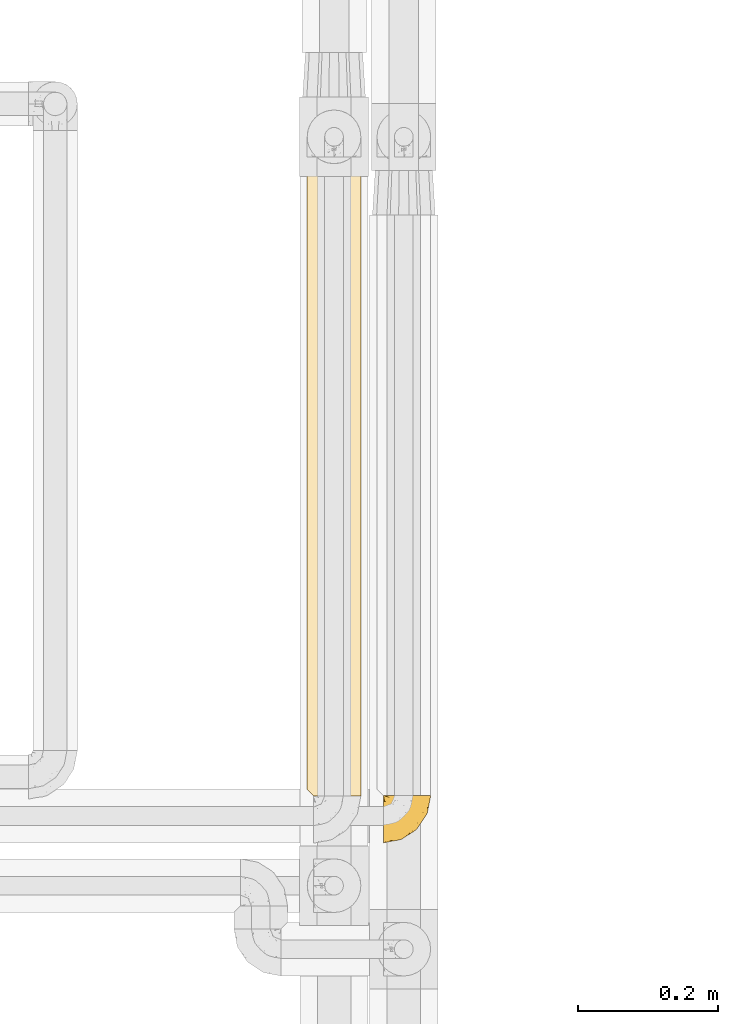
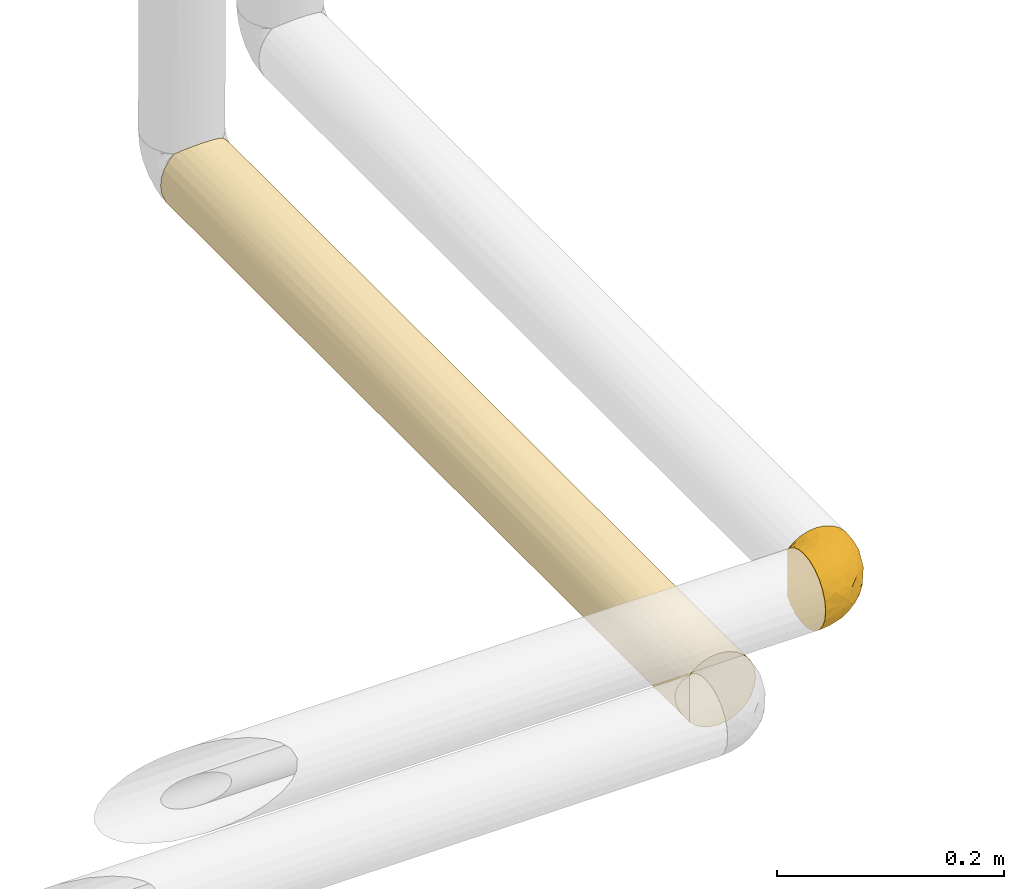
# One storey, part 499 of 827: 2 coverings.
"""IFC2X3 building model written with IfcOpenShell, lengths in millimetres."""

from ifc_helpers import new_model, entity, si_unit, converted_unit, derived_unit, direction, frame, origin, place, context, subcontext, project, spatial, faceted_brep, element, save


model = new_model("IFC2X3")

# Units and contexts
model_context = context("Model", 3, precision=0.01, world=origin(), true_north=direction((6.12303176911189e-17, 1.0)))
body_context = subcontext(model_context, "Body", "Model", "MODEL_VIEW")
ifc_project = project(units=[si_unit("LENGTHUNIT", "METRE", prefix="MILLI"), si_unit("AREAUNIT", "SQUARE_METRE"), si_unit("VOLUMEUNIT", "CUBIC_METRE"), converted_unit("PLANEANGLEUNIT", "DEGREE", entity("IfcRatioMeasure", 0.0174532925199433), si_unit("PLANEANGLEUNIT", "RADIAN"), dimensions=[0, 0, 0, 0, 0, 0, 0]), si_unit("MASSUNIT", "GRAM", prefix="KILO"), derived_unit("MASSDENSITYUNIT", [(si_unit("MASSUNIT", "GRAM", prefix="KILO"), 1), (si_unit("LENGTHUNIT", "METRE"), -3)]), derived_unit("MOMENTOFINERTIAUNIT", [(si_unit("LENGTHUNIT", "METRE"), 4)]), si_unit("TIMEUNIT", "SECOND"), si_unit("FREQUENCYUNIT", "HERTZ"), si_unit("THERMODYNAMICTEMPERATUREUNIT", "DEGREE_CELSIUS"), derived_unit("THERMALTRANSMITTANCEUNIT", [(si_unit("MASSUNIT", "GRAM", prefix="KILO"), 1), (si_unit("THERMODYNAMICTEMPERATUREUNIT", "KELVIN"), -1), (si_unit("TIMEUNIT", "SECOND"), -3)]), derived_unit("VOLUMETRICFLOWRATEUNIT", [(si_unit("LENGTHUNIT", "METRE"), 3), (si_unit("TIMEUNIT", "SECOND"), -1)]), derived_unit("MASSFLOWRATEUNIT", [(si_unit("MASSUNIT", "GRAM", prefix="KILO"), 1), (si_unit("TIMEUNIT", "SECOND"), -1)]), derived_unit("ROTATIONALFREQUENCYUNIT", [(si_unit("TIMEUNIT", "SECOND"), -1)]), si_unit("ELECTRICCURRENTUNIT", "AMPERE"), si_unit("ELECTRICVOLTAGEUNIT", "VOLT"), si_unit("POWERUNIT", "WATT"), si_unit("FORCEUNIT", "NEWTON", prefix="KILO"), si_unit("ILLUMINANCEUNIT", "LUX"), si_unit("LUMINOUSFLUXUNIT", "LUMEN"), si_unit("LUMINOUSINTENSITYUNIT", "CANDELA"), derived_unit("USERDEFINED", [(si_unit("MASSUNIT", "GRAM", prefix="KILO"), -1), (si_unit("LENGTHUNIT", "METRE"), -2), (si_unit("TIMEUNIT", "SECOND"), 3), (si_unit("LUMINOUSFLUXUNIT", "LUMEN"), 1)]), derived_unit("LINEARVELOCITYUNIT", [(si_unit("LENGTHUNIT", "METRE"), 1), (si_unit("TIMEUNIT", "SECOND"), -1)]), si_unit("PRESSUREUNIT", "PASCAL"), derived_unit("USERDEFINED", [(si_unit("LENGTHUNIT", "METRE"), -2), (si_unit("MASSUNIT", "GRAM", prefix="KILO"), 1), (si_unit("TIMEUNIT", "SECOND"), -2)]), derived_unit("LINEARFORCEUNIT", [(si_unit("MASSUNIT", "GRAM", prefix="KILO"), 1), (si_unit("LENGTHUNIT", "METRE"), 1), (si_unit("TIMEUNIT", "SECOND"), -2), (si_unit("LENGTHUNIT", "METRE"), -1)]), derived_unit("PLANARFORCEUNIT", [(si_unit("MASSUNIT", "GRAM", prefix="KILO"), 1), (si_unit("LENGTHUNIT", "METRE"), 1), (si_unit("TIMEUNIT", "SECOND"), -2), (si_unit("LENGTHUNIT", "METRE"), -2)])], contexts=[model_context])

# Site, building, storey
site_placement = place(None, origin())
site = spatial("IfcSite", under=ifc_project, at=site_placement, CompositionType="ELEMENT")
building_placement = place(site_placement, origin())
building = spatial("IfcBuilding", under=site, at=building_placement, CompositionType="ELEMENT")
storey_placement = place(building_placement, frame((0.0, 0.0, 28200.0)))
storey = spatial("IfcBuildingStorey", under=building, at=storey_placement, Name="08", CompositionType="ELEMENT", Elevation=28200.0)

# Coverings
covering_1_placement = place(storey_placement, frame((61121.94, 16439.61, 1059.95)))
element("IfcCovering", 1, at=covering_1_placement, inside=storey, Name=":ADSK_", ObjectType=":ADSK_", PredefinedType="INSULATION", context=body_context, shape_type="Brep", body=[
    faceted_brep([(47.38, 69.15, 74.68), (54.67, 69.15, 70.1), (60.76, 69.15, 64.01), (65.34, 69.15, 56.72), (68.18, 69.15, 48.6), (69.15, 69.15, 40.05), (68.18, 69.15, 31.49), (65.33, 69.15, 23.36), (60.75, 69.15, 16.07), (54.66, 69.15, 9.98), (47.37, 69.15, 5.4), (39.25, 69.15, 2.56), (30.7, 69.15, 1.6), (22.59, 69.15, 2.46), (14.86, 69.15, 5.01), (7.84, 69.15, 9.13), (1.85, 69.15, 14.62), (1.85, 69.15, 16.82), (1.85, 69.15, 18.56), (1.85, 69.15, 20.52), (1.85, 69.15, 22.49), (1.85, 69.15, 24.46), (1.85, 69.15, 26.42), (1.85, 69.15, 28.39), (1.85, 69.15, 30.36), (1.85, 69.15, 32.55), (1.85, 69.15, 34.75), (1.85, 69.15, 36.94), (1.85, 69.15, 39.13), (1.85, 69.15, 41.33), (1.85, 69.15, 43.52), (1.85, 69.15, 45.72), (1.85, 69.15, 47.91), (1.85, 69.15, 50.11), (1.85, 69.15, 52.3), (1.85, 69.15, 54.49), (1.85, 69.15, 56.69), (1.85, 69.15, 58.88), (1.85, 69.15, 61.08), (1.85, 69.15, 63.27), (1.85, 69.15, 65.47), (7.85, 69.15, 70.97), (14.88, 69.15, 75.09), (22.61, 69.15, 77.64), (30.7, 69.15, 78.5), (39.26, 69.15, 77.53), (1.6, 68.89, 14.62), (1.6, 62.89, 9.12), (1.6, 55.87, 5.0), (1.6, 48.14, 2.46), (1.6, 40.05, 1.6), (1.6, 30.09, 2.91), (1.6, 20.82, 6.75), (1.6, 12.86, 12.86), (1.6, 6.75, 20.82), (1.6, 2.91, 30.09), (1.6, 1.6, 40.05), (1.6, 2.91, 50.0), (1.6, 6.75, 59.27), (1.6, 12.86, 67.23), (1.6, 20.82, 73.34), (1.6, 30.09, 77.19), (1.6, 40.05, 78.5), (1.6, 48.14, 77.63), (1.6, 55.87, 75.09), (1.6, 62.89, 70.97), (1.6, 68.89, 65.47), (1.6, 68.89, 63.27), (1.6, 68.89, 62.29), (1.6, 68.89, 60.7), (1.6, 68.89, 59.11), (1.6, 68.89, 57.52), (1.6, 68.89, 55.93), (1.6, 68.89, 54.34), (1.6, 68.89, 52.76), (1.6, 68.89, 51.17), (1.6, 68.89, 49.58), (1.6, 68.89, 47.99), (1.6, 68.89, 46.4), (1.6, 68.89, 44.81), (1.6, 68.89, 43.22), (1.6, 68.89, 41.63), (1.6, 68.89, 40.05), (1.6, 68.89, 38.46), (1.6, 68.89, 36.87), (1.6, 68.89, 35.28), (1.6, 68.89, 33.69), (1.6, 68.89, 32.1), (1.6, 68.89, 30.51), (1.6, 68.89, 28.92), (1.6, 68.89, 27.33), (1.6, 68.89, 25.37), (1.6, 68.89, 23.4), (1.6, 68.89, 21.21), (1.6, 68.89, 19.01), (1.6, 68.89, 16.82), (1.78, 68.97, 42.32), (1.77, 68.96, 44.02), (1.78, 68.97, 47.13), (1.77, 68.97, 48.74), (1.79, 68.98, 23.57), (1.78, 68.97, 25.13), (1.76, 68.96, 61.34), (1.77, 68.96, 22.02), (1.77, 68.96, 29.72), (1.76, 68.96, 56.73), (1.77, 68.96, 55.14), (1.77, 68.96, 37.66), (1.8, 69.0, 64.12), (1.76, 68.96, 28.13), (1.77, 68.96, 26.62), (1.78, 68.97, 31.46), (1.77, 68.96, 16.16), (1.77, 68.96, 39.16), (1.76, 68.96, 50.37), (1.77, 68.97, 17.69), (1.78, 68.97, 19.17), (1.77, 68.97, 62.78), (1.77, 68.96, 58.35), (1.77, 68.96, 45.53), (1.78, 68.97, 59.91), (1.77, 68.97, 65.47), (1.8, 69.02, 65.47), (1.82, 69.08, 65.47), (1.77, 68.97, 14.62), (1.72, 68.94, 14.62), (1.66, 68.92, 14.62), (1.76, 68.96, 20.59), (1.77, 68.96, 32.99), (1.76, 68.95, 34.48), (1.77, 68.96, 51.91), (1.66, 68.92, 65.47), (1.72, 68.94, 65.47), (1.78, 68.98, 53.48), (1.82, 69.08, 14.62), (1.8, 69.02, 14.62), (1.77, 68.96, 40.77), (1.78, 68.97, 35.97), (3.72, 61.33, 7.84), (7.41, 53.1, 3.53), (6.13, 63.33, 8.32), (21.47, 49.27, 1.6), (19.34, 55.53, 2.19), (26.8, 54.6, 1.6), (8.87, 41.99, 1.6), (9.2, 57.07, 4.57), (12.79, 57.95, 3.96), (14.62, 51.56, 2.28), (7.34, 41.58, 1.6), (5.33, 61.7, 7.69), (17.64, 63.33, 3.53), (7.7, 65.0, 8.32), (9.41, 67.02, 7.84), (28.75, 61.87, 1.6), (16.15, 43.94, 1.6), (14.14, 61.21, 4.34), (29.16, 63.4, 1.6), (57.02, 33.11, 29.63), (64.92, 52.82, 27.34), (64.0, 43.3, 40.05), (11.92, 33.73, 2.39), (19.16, 36.52, 2.43), (28.65, 24.87, 9.07), (24.62, 14.17, 16.64), (15.19, 18.43, 9.54), (18.36, 28.67, 4.52), (9.2, 26.0, 4.52), (46.98, 49.25, 7.49), (50.24, 59.72, 7.49), (56.1, 55.1, 12.85), (28.97, 44.72, 2.35), (54.46, 34.15, 22.66), (21.34, 5.25, 32.9), (18.4, 6.75, 25.33), (66.44, 55.54, 40.05), (12.07, 10.47, 16.64), (45.49, 25.49, 19.99), (50.57, 35.53, 16.37), (36.04, 48.22, 3.26), (42.07, 58.71, 3.75), (62.12, 57.42, 19.58), (37.37, 34.84, 7.5), (29.39, 36.87, 4.04), (53.59, 45.01, 13.94), (58.06, 44.4, 19.58), (49.27, 23.96, 28.21), (29.63, 11.2, 24.75), (33.21, 10.56, 31.42), (40.1, 16.81, 26.2), (44.08, 17.38, 33.36), (49.36, 21.38, 40.05), (56.68, 32.34, 40.05), (15.2, 4.3, 40.05), (35.57, 20.65, 16.14), (41.7, 29.66, 12.85), (46.4, 39.6, 10.47), (41.41, 42.55, 6.49), (27.45, 6.74, 40.05), (38.4, 14.06, 40.05), (12.99, 26.84, 75.57), (21.33, 5.28, 47.37), (42.89, 18.52, 52.91), (57.04, 33.13, 50.46), (56.11, 55.1, 67.23), (62.13, 57.43, 60.5), (21.89, 20.72, 70.55), (16.62, 11.46, 63.45), (32.9, 17.69, 62.61), (46.99, 49.26, 72.6), (50.25, 59.73, 72.6), (42.08, 58.71, 76.34), (49.91, 29.72, 59.34), (15.6, 35.35, 77.76), (16.15, 43.94, 78.5), (8.87, 41.99, 78.5), (29.16, 63.4, 78.5), (13.16, 4.93, 53.16), (10.83, 17.46, 70.55), (33.8, 10.94, 48.88), (25.02, 8.92, 54.76), (64.92, 52.83, 52.74), (32.83, 29.34, 71.93), (20.56, 30.26, 75.79), (58.07, 44.4, 60.5), (21.46, 39.06, 77.86), (28.1, 43.06, 77.64), (26.8, 54.6, 78.5), (21.47, 49.27, 78.5), (51.29, 42.69, 67.23), (36.04, 48.2, 76.82), (28.75, 61.87, 78.5), (8.45, 33.44, 77.8), (41.73, 29.67, 67.23), (39.27, 38.5, 73.2), (33.56, 23.35, 67.66), (27.29, 34.97, 75.99), (7.41, 53.1, 76.57), (3.51, 59.68, 73.21), (4.68, 62.19, 71.93), (5.52, 64.11, 71.07), (8.75, 57.97, 75.09), (12.79, 57.95, 76.13), (17.65, 63.33, 76.57), (13.9, 51.77, 77.69), (9.42, 67.02, 72.26), (7.68, 64.98, 71.77), (19.33, 55.53, 77.9), (14.13, 61.22, 75.75)], [[[0, 1, 2, 3, 4, 5, 6, 7, 8, 9, 10, 11, 12, 13, 14, 15, 16, 17, 18, 19, 20, 21, 22, 23, 24, 25, 26, 27, 28, 29, 30, 31, 32, 33, 34, 35, 36, 37, 38, 39, 40, 41, 42, 43, 44, 45]], [[46, 47, 48, 49, 50, 51, 52, 53, 54, 55, 56, 57, 58, 59, 60, 61, 62, 63, 64, 65, 66, 67, 68, 69, 70, 71, 72, 73, 74, 75, 76, 77, 78, 79, 80, 81, 82, 83, 84, 85, 86, 87, 88, 89, 90, 91, 92, 93, 94, 95]], [[96, 97, 30]], [[98, 77, 99]], [[100, 101, 21]], [[69, 68, 102]], [[20, 19, 103]], [[24, 23, 104]], [[20, 103, 100]], [[72, 105, 106]], [[84, 83, 107]], [[89, 88, 104]], [[108, 67, 66]], [[109, 110, 90]], [[111, 25, 24]], [[112, 17, 16]], [[82, 113, 83]], [[109, 23, 22]], [[114, 76, 75]], [[105, 36, 106]], [[104, 111, 24]], [[18, 115, 116]], [[97, 96, 80]], [[67, 108, 117]], [[105, 71, 118]], [[31, 97, 119]], [[102, 120, 69]], [[108, 121, 122, 123, 40]], [[112, 95, 115]], [[17, 115, 18]], [[94, 116, 115]], [[117, 68, 67]], [[38, 117, 39]], [[112, 124, 125, 126, 46]], [[17, 112, 115]], [[70, 120, 118]], [[39, 117, 108]], [[120, 38, 37]], [[120, 37, 118]], [[120, 70, 69]], [[116, 94, 127]], [[128, 86, 129]], [[117, 38, 102]], [[74, 130, 75]], [[99, 33, 32]], [[115, 95, 94]], [[39, 108, 40]], [[108, 66, 131, 132, 121]], [[105, 72, 71]], [[118, 37, 36]], [[71, 70, 118]], [[35, 106, 36]], [[36, 105, 118]], [[35, 133, 106]], [[74, 73, 133]], [[106, 133, 73]], [[99, 114, 33]], [[133, 35, 34]], [[73, 72, 106]], [[95, 112, 46]], [[112, 16, 134, 135, 124]], [[130, 114, 75]], [[99, 76, 114]], [[114, 130, 33]], [[34, 33, 130]], [[78, 77, 98]], [[98, 119, 78]], [[130, 133, 34]], [[133, 130, 74]], [[79, 97, 80]], [[98, 99, 32]], [[98, 32, 31]], [[77, 76, 99]], [[97, 79, 119]], [[136, 96, 29]], [[30, 97, 31]], [[136, 29, 28]], [[81, 80, 96]], [[29, 96, 30]], [[31, 119, 98]], [[119, 79, 78]], [[96, 136, 81]], [[82, 81, 136]], [[113, 107, 83]], [[84, 107, 137]], [[107, 27, 137]], [[113, 28, 107]], [[27, 107, 28]], [[85, 84, 137]], [[137, 27, 26]], [[113, 136, 28]], [[136, 113, 82]], [[109, 89, 104]], [[86, 85, 129]], [[89, 109, 90]], [[111, 87, 128]], [[26, 129, 137]], [[88, 111, 104]], [[25, 111, 128]], [[22, 110, 109]], [[23, 109, 104]], [[110, 91, 90]], [[100, 92, 101]], [[110, 22, 101]], [[91, 110, 101]], [[116, 19, 18]], [[111, 88, 87]], [[127, 103, 19]], [[25, 128, 26]], [[86, 128, 87]], [[128, 129, 26]], [[137, 129, 85]], [[120, 102, 38]], [[117, 102, 68]], [[91, 101, 92]], [[21, 101, 22]], [[93, 92, 103]], [[100, 21, 20]], [[100, 103, 92]], [[127, 93, 103]], [[93, 127, 94]], [[116, 127, 19]], [[126, 138, 47]], [[48, 138, 139]], [[140, 125, 124]], [[141, 142, 143]], [[144, 49, 139]], [[145, 140, 146]], [[48, 139, 49]], [[139, 145, 147]], [[49, 144, 148, 50]], [[126, 125, 149]], [[14, 13, 150]], [[151, 146, 140]], [[149, 140, 145]], [[152, 151, 135]], [[152, 14, 150]], [[16, 15, 134]], [[13, 153, 150]], [[124, 151, 140]], [[141, 147, 142]], [[14, 152, 15]], [[15, 152, 134]], [[47, 46, 126]], [[139, 154, 144]], [[138, 48, 47]], [[125, 140, 149]], [[135, 134, 152]], [[146, 155, 142]], [[145, 146, 147]], [[149, 139, 138]], [[147, 141, 154]], [[147, 146, 142]], [[139, 147, 154]], [[139, 149, 145]], [[149, 138, 126]], [[155, 146, 151]], [[150, 143, 142]], [[152, 155, 151]], [[150, 142, 155]], [[13, 12, 156, 153]], [[153, 143, 150]], [[152, 150, 155]], [[151, 124, 135]], [[157, 158, 159]], [[160, 154, 161]], [[162, 163, 164]], [[165, 166, 160]], [[167, 168, 169]], [[141, 170, 161]], [[156, 12, 11]], [[158, 157, 171]], [[172, 55, 173]], [[158, 6, 174]], [[175, 54, 53]], [[52, 166, 164]], [[52, 164, 53]], [[54, 175, 173]], [[166, 52, 51]], [[176, 177, 171]], [[178, 143, 179]], [[156, 11, 179]], [[8, 7, 180]], [[169, 9, 8]], [[179, 143, 153, 156]], [[179, 11, 10]], [[168, 179, 10]], [[181, 162, 182]], [[179, 167, 178]], [[183, 184, 177]], [[183, 169, 184]], [[176, 171, 185]], [[172, 186, 187]], [[158, 7, 6]], [[159, 158, 174]], [[184, 180, 158]], [[54, 173, 55]], [[180, 169, 8]], [[188, 189, 187]], [[9, 168, 10]], [[186, 188, 187]], [[190, 157, 159, 191]], [[55, 172, 192]], [[176, 193, 194]], [[161, 170, 182]], [[162, 164, 165]], [[175, 164, 163]], [[51, 50, 148]], [[167, 195, 196]], [[178, 182, 170]], [[6, 5, 174]], [[158, 180, 7]], [[169, 180, 184]], [[169, 168, 9]], [[179, 168, 167]], [[182, 162, 165]], [[162, 194, 193]], [[161, 165, 160]], [[195, 181, 196]], [[192, 172, 197]], [[192, 56, 55]], [[189, 190, 198]], [[198, 197, 187]], [[172, 187, 197]], [[185, 189, 188]], [[198, 187, 189]], [[186, 172, 173]], [[173, 163, 186]], [[193, 186, 163]], [[176, 185, 188]], [[185, 157, 190]], [[188, 186, 193]], [[177, 176, 194]], [[188, 193, 176]], [[162, 193, 163]], [[195, 177, 194]], [[171, 177, 184]], [[181, 195, 194]], [[183, 167, 169]], [[162, 181, 194]], [[196, 182, 178]], [[158, 171, 184]], [[171, 157, 185]], [[177, 195, 183]], [[167, 183, 195]], [[182, 196, 181]], [[178, 170, 143]], [[178, 167, 196]], [[164, 175, 53]], [[173, 175, 163]], [[160, 51, 148]], [[164, 166, 165]], [[51, 160, 166]], [[160, 148, 144, 154]], [[141, 161, 154]], [[182, 165, 161]], [[190, 189, 185]], [[143, 170, 141]], [[60, 199, 61]], [[197, 200, 192]], [[201, 190, 202]], [[200, 57, 192]], [[203, 204, 2]], [[205, 206, 207]], [[208, 209, 210]], [[211, 207, 201]], [[212, 213, 214]], [[45, 215, 210]], [[216, 206, 58]], [[45, 44, 215]], [[59, 217, 60]], [[60, 217, 199]], [[0, 45, 210]], [[218, 201, 219]], [[202, 159, 220]], [[205, 221, 222]], [[223, 204, 203]], [[1, 203, 2]], [[57, 200, 216]], [[220, 3, 204]], [[220, 174, 4]], [[1, 0, 209]], [[212, 224, 213]], [[225, 226, 227]], [[228, 223, 203]], [[208, 210, 229]], [[210, 226, 229]], [[3, 220, 4]], [[58, 206, 59]], [[209, 203, 1]], [[202, 220, 223]], [[228, 203, 208]], [[202, 211, 201]], [[3, 2, 204]], [[202, 190, 191, 159]], [[210, 215, 230, 226]], [[199, 212, 231]], [[232, 233, 221]], [[233, 208, 229]], [[207, 206, 219]], [[217, 206, 205]], [[227, 224, 225]], [[233, 232, 228]], [[201, 207, 219]], [[234, 232, 221]], [[218, 219, 200]], [[202, 223, 211]], [[174, 220, 159]], [[174, 5, 4]], [[61, 231, 62]], [[220, 204, 223]], [[210, 209, 0]], [[203, 209, 208]], [[225, 233, 229]], [[224, 227, 213]], [[221, 233, 235]], [[57, 56, 192]], [[198, 218, 197]], [[200, 219, 216]], [[201, 198, 190]], [[197, 218, 200]], [[198, 201, 218]], [[206, 216, 219]], [[58, 57, 216]], [[231, 212, 214]], [[222, 212, 199]], [[228, 211, 223]], [[207, 211, 232]], [[62, 231, 214]], [[199, 231, 61]], [[233, 228, 208]], [[211, 228, 232]], [[222, 221, 235]], [[234, 205, 207]], [[206, 217, 59]], [[199, 217, 205]], [[205, 222, 199]], [[224, 222, 235]], [[222, 224, 212]], [[224, 235, 225]], [[233, 225, 235]], [[226, 225, 229]], [[205, 234, 221]], [[207, 232, 234]], [[63, 214, 236]], [[214, 213, 236]], [[214, 63, 62]], [[237, 236, 238]], [[238, 132, 131]], [[236, 237, 64]], [[239, 240, 241]], [[63, 236, 64]], [[131, 66, 65]], [[237, 131, 65]], [[242, 230, 43]], [[237, 65, 64]], [[239, 121, 132]], [[42, 242, 43]], [[241, 240, 243]], [[41, 123, 244]], [[43, 230, 215, 44]], [[244, 122, 245]], [[227, 246, 243]], [[241, 247, 245]], [[121, 239, 245]], [[41, 40, 123]], [[132, 238, 239]], [[244, 42, 41]], [[131, 237, 238]], [[240, 239, 238]], [[245, 239, 241]], [[247, 241, 246]], [[247, 244, 245]], [[238, 236, 240]], [[243, 236, 213]], [[236, 243, 240]], [[227, 226, 246]], [[243, 213, 227]], [[242, 246, 226]], [[243, 246, 241]], [[246, 242, 247]], [[244, 247, 242]], [[242, 226, 230]], [[42, 244, 242]], [[122, 244, 123]], [[122, 121, 245]]]),
])
covering_2_placement = place(storey_placement, frame((61012.64, 16506.66, 960.01)))
element("IfcCovering", 2, at=covering_2_placement, inside=storey, Name=":ADSK_", ObjectType=":ADSK_", PredefinedType="INSULATION", context=body_context, shape_type="Brep", body=[
    faceted_brep([(31.79, 1.6, 2.48), (40.0, 1.6, 1.6), (49.93, 1.6, 2.9), (59.2, 1.6, 6.74), (67.15, 1.6, 12.84), (73.25, 1.6, 20.8), (77.09, 1.6, 30.06), (78.4, 1.6, 40.0), (77.09, 1.6, 49.93), (73.25, 1.6, 59.2), (67.15, 1.6, 67.15), (59.2, 1.6, 73.25), (49.93, 1.6, 77.09), (40.0, 1.6, 78.4), (31.8, 1.6, 77.51), (23.99, 1.6, 74.9), (16.92, 1.6, 70.69), (10.9, 1.6, 65.06), (10.89, 1.6, 14.95), (16.9, 1.6, 9.32), (23.98, 1.6, 5.1), (30.06, 917.07, 2.9), (20.8, 917.07, 6.74), (12.84, 917.07, 12.84), (6.74, 917.07, 20.8), (2.9, 917.07, 30.06), (1.6, 917.07, 40.0), (2.48, 917.07, 48.2), (5.09, 917.07, 56.01), (9.31, 917.07, 63.08), (14.94, 917.07, 69.1), (65.05, 917.07, 69.1), (70.68, 917.07, 63.08), (74.9, 917.07, 56.01), (77.51, 917.07, 48.2), (78.4, 917.07, 40.0), (77.09, 917.07, 30.06), (73.25, 917.07, 20.8), (67.15, 917.07, 12.84), (59.2, 917.07, 6.74), (49.93, 917.07, 2.9), (40.0, 917.07, 1.6), (2.98, 317.39, 29.79), (1.6, 443.64, 40.0), (2.24, 572.17, 32.99), (4.52, 637.02, 25.3), (9.1, 706.72, 17.2), (13.93, 338.17, 11.79), (3.99, 8.49, 26.64), (2.2, 10.29, 33.21), (25.3, 669.77, 4.52), (14.42, 620.17, 11.35), (29.81, 326.15, 2.97), (40.0, 217.97, 1.6), (5.65, 346.24, 22.81), (1.6, 227.27, 40.0), (8.87, 222.56, 17.51), (6.92, 5.56, 20.49), (8.97, 462.58, 17.37), (32.79, 567.52, 2.28), (40.0, 700.7, 1.6), (1.6, 700.7, 40.0), (20.32, 432.38, 7.02), (40.0, 434.34, 1.6), (20.32, 200.56, 7.02), (1.6, 680.35, 40.0), (1.6, 10.9, 40.0), (63.37, 459.33, 9.53), (54.69, 299.22, 4.52), (54.69, 625.12, 4.52), (63.37, 207.54, 9.53), (70.46, 285.0, 16.62), (47.18, 338.14, 2.27), (46.92, 567.52, 2.23), (63.37, 711.12, 9.53), (70.46, 619.44, 16.62), (77.68, 592.51, 32.61), (75.47, 416.82, 25.3), (75.47, 687.92, 25.3), (76.29, 207.08, 27.45), (77.76, 351.04, 33.03), (78.4, 700.7, 40.0), (78.4, 217.97, 40.0), (78.4, 484.32, 40.0), (78.4, 242.96, 40.0), (72.98, 718.13, 59.66), (76.41, 652.49, 52.17), (57.18, 572.4, 74.33), (54.69, 281.83, 75.47), (62.63, 456.04, 71.02), (76.92, 328.66, 50.54), (68.2, 580.47, 66.05), (46.78, 908.37, 77.79), (40.0, 691.4, 78.4), (50.2, 601.18, 77.01), (73.43, 244.57, 58.88), (72.98, 486.37, 59.66), (68.65, 298.49, 65.56), (62.49, 696.09, 71.11), (40.0, 475.03, 78.4), (47.0, 346.5, 77.75), (53.36, 910.17, 76.0), (62.8, 211.84, 70.89), (40.0, 217.97, 78.4), (59.51, 913.1, 73.07), (40.0, 907.77, 78.4), (33.21, 908.37, 77.79), (2.2, 10.29, 46.79), (8.98, 455.12, 62.64), (8.88, 218.63, 62.5), (15.44, 331.33, 69.52), (27.82, 238.01, 76.41), (11.14, 682.91, 65.33), (23.28, 461.67, 74.57), (29.8, 651.15, 77.02), (23.41, 725.44, 74.63), (26.63, 910.17, 76.0), (17.47, 657.07, 71.1), (30.15, 438.78, 77.11), (6.73, 642.89, 59.18), (5.66, 340.55, 57.18), (6.93, 5.57, 59.52), (20.75, 202.58, 73.22), (20.48, 913.1, 73.07), (3.58, 626.19, 52.17), (2.98, 317.57, 50.21), (4.0, 8.5, 53.36)], [[[0, 1, 2, 3, 4, 5, 6, 7, 8, 9, 10, 11, 12, 13, 14, 15, 16, 17, 18, 19, 20]], [[21, 22, 23, 24, 25, 26, 27, 28, 29, 30, 31, 32, 33, 34, 35, 36, 37, 38, 39, 40, 41]], [[42, 43, 44]], [[45, 24, 46]], [[44, 25, 45]], [[24, 45, 25]], [[18, 47, 19]], [[42, 48, 49]], [[50, 51, 22]], [[0, 52, 53]], [[48, 42, 54]], [[51, 46, 23]], [[49, 55, 42]], [[56, 18, 57]], [[54, 58, 56]], [[52, 50, 59]], [[22, 21, 50]], [[21, 41, 60]], [[54, 45, 58]], [[25, 44, 61]], [[62, 47, 51]], [[63, 53, 52]], [[64, 20, 19]], [[57, 48, 54]], [[0, 53, 1]], [[0, 20, 52]], [[62, 51, 50]], [[56, 58, 47]], [[56, 47, 18]], [[51, 47, 58]], [[20, 64, 52]], [[47, 62, 64]], [[46, 51, 58]], [[22, 51, 23]], [[60, 59, 21]], [[52, 62, 50]], [[59, 60, 63]], [[47, 64, 19]], [[52, 64, 62]], [[44, 43, 65, 61]], [[61, 26, 25]], [[42, 44, 45]], [[52, 59, 63]], [[21, 59, 50]], [[54, 56, 57]], [[45, 54, 42]], [[45, 46, 58]], [[23, 46, 24]], [[55, 49, 66]], [[55, 43, 42]], [[67, 68, 69]], [[70, 71, 4]], [[72, 73, 68]], [[70, 68, 67]], [[39, 69, 40]], [[73, 63, 60]], [[38, 74, 39]], [[2, 53, 72]], [[70, 4, 3]], [[3, 2, 68]], [[37, 75, 38]], [[75, 71, 70, 67, 74]], [[76, 77, 78]], [[78, 75, 37]], [[41, 40, 60]], [[53, 2, 1]], [[79, 77, 80]], [[77, 79, 71]], [[5, 4, 71]], [[36, 78, 37]], [[36, 35, 81]], [[82, 7, 6]], [[63, 73, 72]], [[71, 75, 78, 77]], [[69, 39, 74]], [[79, 80, 82]], [[73, 40, 69]], [[81, 76, 36]], [[80, 77, 76]], [[76, 81, 83]], [[80, 83, 84, 82]], [[36, 76, 78]], [[40, 73, 60]], [[68, 73, 69]], [[68, 2, 72]], [[68, 70, 3]], [[53, 63, 72]], [[75, 74, 38]], [[69, 74, 67]], [[83, 80, 76]], [[79, 82, 6]], [[6, 5, 79]], [[71, 79, 5]], [[85, 86, 33]], [[87, 88, 89]], [[33, 32, 85]], [[83, 86, 90]], [[32, 31, 91]], [[92, 93, 94]], [[34, 86, 81]], [[8, 90, 95]], [[96, 91, 97]], [[96, 90, 86]], [[8, 84, 90]], [[91, 31, 98]], [[94, 99, 100]], [[101, 94, 87]], [[95, 97, 9]], [[34, 33, 86]], [[97, 102, 10]], [[94, 101, 92]], [[86, 83, 81]], [[87, 89, 98]], [[11, 102, 88]], [[98, 89, 91]], [[99, 103, 100]], [[88, 12, 11]], [[104, 101, 87]], [[97, 95, 96]], [[104, 98, 31]], [[81, 35, 34]], [[13, 12, 103]], [[97, 91, 89]], [[91, 96, 85]], [[102, 97, 89]], [[9, 97, 10]], [[91, 85, 32]], [[86, 85, 96]], [[100, 12, 88]], [[12, 100, 103]], [[94, 100, 88]], [[87, 98, 104]], [[88, 87, 94]], [[88, 102, 89]], [[10, 102, 11]], [[8, 95, 9]], [[90, 96, 95]], [[93, 92, 105]], [[93, 99, 94]], [[8, 7, 82, 84]], [[84, 83, 90]], [[105, 106, 93]], [[107, 55, 66]], [[108, 109, 110]], [[14, 111, 15]], [[112, 30, 29]], [[113, 114, 115]], [[114, 106, 116]], [[17, 110, 109]], [[117, 110, 113]], [[118, 114, 113]], [[116, 115, 114]], [[119, 108, 112]], [[14, 103, 111]], [[120, 121, 109]], [[15, 111, 122]], [[120, 109, 108]], [[123, 30, 117]], [[124, 125, 120]], [[27, 124, 28]], [[93, 106, 114]], [[125, 55, 107]], [[27, 65, 124]], [[121, 17, 109]], [[117, 115, 123]], [[43, 125, 124]], [[126, 125, 107]], [[28, 124, 119]], [[126, 121, 120]], [[117, 112, 110]], [[14, 13, 103]], [[112, 108, 110]], [[110, 17, 16]], [[93, 114, 99]], [[122, 16, 15]], [[110, 122, 113]], [[113, 111, 118]], [[118, 103, 99]], [[120, 108, 119]], [[126, 120, 125]], [[113, 122, 111]], [[16, 122, 110]], [[103, 118, 111]], [[99, 114, 118]], [[125, 43, 55]], [[30, 112, 117]], [[29, 28, 119]], [[119, 112, 29]], [[120, 119, 124]], [[123, 115, 116]], [[113, 115, 117]], [[27, 26, 61, 65]], [[65, 43, 124]], [[107, 66, 49, 48, 57, 18, 17, 121, 126]], [[123, 116, 106, 105, 92, 101, 104, 31, 30]]]),
])

save(model, "model.ifc")
